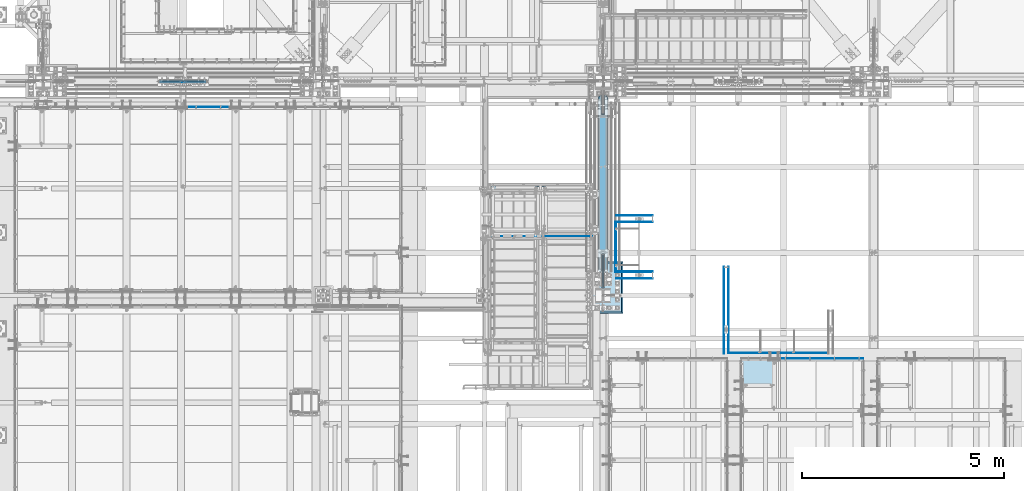
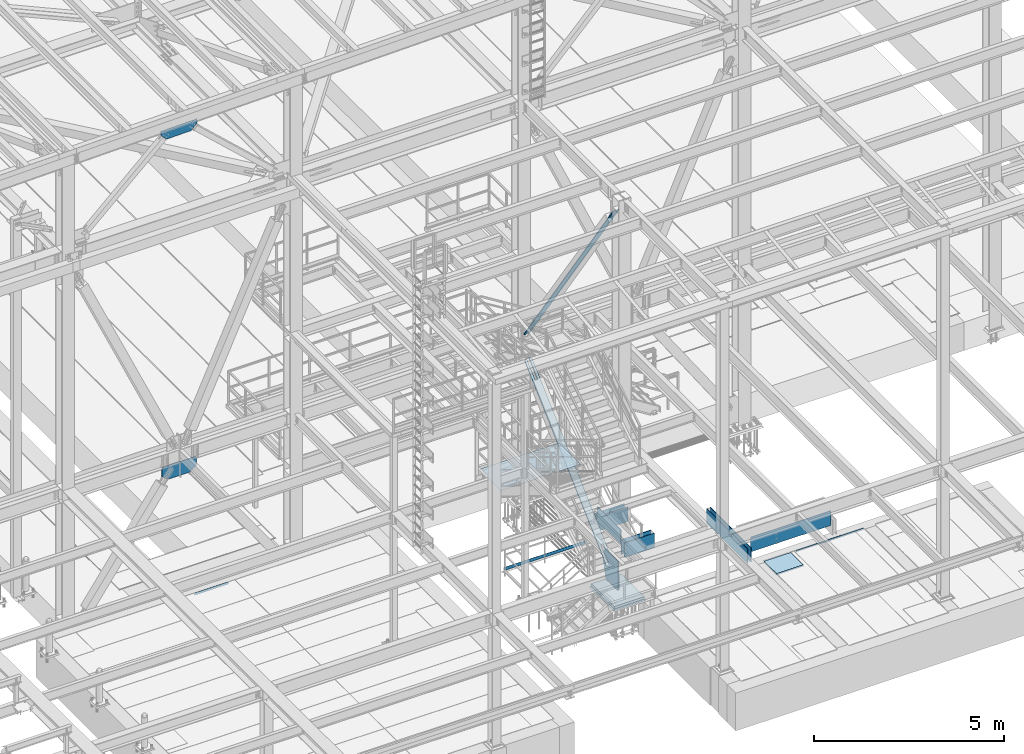
# One storey, part 2971 of 3843: 20 plates, 19 elements without a shape of their own.
"""IFC2X3 building model written with IfcOpenShell, lengths in millimetres."""

from ifc_helpers import new_model, si_unit, frame, origin_with_axes, place, context, subcontext, project, spatial, faceted_brep, material, type_object, element, aggregate, save


model = new_model("IFC2X3")

# Units and contexts
model_context = context("Model", 3, precision=1e-05, world=origin_with_axes())
body_context = subcontext(model_context, "Body", "Model", "MODEL_VIEW")
ifc_project = project(units=[si_unit("LENGTHUNIT", "METRE", prefix="MILLI"), si_unit("AREAUNIT", "SQUARE_METRE"), si_unit("VOLUMEUNIT", "CUBIC_METRE"), si_unit("MASSUNIT", "GRAM", prefix="KILO"), si_unit("TIMEUNIT", "SECOND"), si_unit("PLANEANGLEUNIT", "RADIAN"), si_unit("SOLIDANGLEUNIT", "STERADIAN"), si_unit("THERMODYNAMICTEMPERATUREUNIT", "DEGREE_CELSIUS"), si_unit("LUMINOUSINTENSITYUNIT", "LUMEN")], contexts=[model_context])

# Site, building, storey
site_placement = place(None, origin_with_axes())
site = spatial("IfcSite", under=ifc_project, at=site_placement, CompositionType="ELEMENT")
building_placement = place(site_placement, origin_with_axes())
building = spatial("IfcBuilding", under=site, at=building_placement, Name="Undefined", CompositionType="ELEMENT")
storey_placement = place(building_placement, origin_with_axes())
storey = spatial("IfcBuildingStorey", under=building, at=storey_placement, Name="Undefined", CompositionType="ELEMENT", Elevation=0.0)

# Assembly, plate
assembly_1_placement = place(storey_placement, origin_with_axes())
assembly_1 = element("IfcElementAssembly", 1, at=assembly_1_placement, inside=storey, AssemblyPlace="NOTDEFINED", PredefinedType="NOTDEFINED")
ifc_material_1 = material(Name="Drywall")
plate_type_1 = type_object("IfcPlateType", PredefinedType="NOTDEFINED")
plate_1_placement = place(assembly_1_placement, frame((58921.2137338943, 18872.2000000001, 30714.95), z_axis=(0.99999999999732, 2.31500000154483e-06, 0.0), x_axis=(-2.31499999993709e-06, 0.99999999999732, 0.0)))
plate_1 = element("IfcPlate", 2, at=plate_1_placement, type_object=plate_type_1, material=ifc_material_1, context=body_context, shape_type="Brep", body=[
    faceted_brep([(3.63797880709171e-12, -234.950000000001, -1.45519152283669e-11), (-7.41896983527113e-05, -234.950000000001, 15.8794303937975), (-7.41896983527113e-05, 234.950000000001, 15.8794303937975), (3.63797880709171e-12, 234.950000000001, -1.45519152283669e-11), (2146.3011990534, -234.950000000001, 15.8843994176204), (2146.3011990534, 234.950000000001, 15.8843994176204), (2146.30123583576, -234.950000000001, 3.33966454491019e-09), (2146.30123583576, 234.950000000001, 3.33966454491019e-09)], [[[0, 1, 2, 3]], [[1, 4, 5, 2]], [[4, 6, 7, 5]], [[6, 0, 3, 7]], [[5, 7, 3, 2]], [[6, 4, 1, 0]]]),
])
aggregate(assembly_1, [plate_1])

assembly_2_placement = place(storey_placement, origin_with_axes())
assembly_2 = element("IfcElementAssembly", 3, at=assembly_2_placement, inside=storey, AssemblyPlace="NOTDEFINED", PredefinedType="NOTDEFINED")
plate_2_placement = place(assembly_2_placement, frame((56254.6500010535, 22120.2773570658, 30714.95), z_axis=(4.67099999962315e-06, 0.999999999989091, 0.0), x_axis=(0.999999999985138, -5.45199999894105e-06, 0.0)))
plate_2 = element("IfcPlate", 4, at=plate_2_placement, type_object=plate_type_1, material=ifc_material_1, context=body_context, shape_type="Brep", body=[
    faceted_brep([(3.63797880709171e-12, -234.950000000001, -1.45519152283669e-11), (-7.41896983527113e-05, -234.950000000001, 15.8794303937975), (-7.41896983527113e-05, 234.950000000001, 15.8794303937975), (3.63797880709171e-12, 234.950000000001, -1.45519152283669e-11), (911.293316277799, -234.950000000001, 15.8843994149647), (911.293316277799, 234.950000000001, 15.8843994149647), (911.293402881587, -234.950000000001, 1.12049747258425e-09), (911.293402881587, 234.950000000001, 1.12049747258425e-09)], [[[0, 1, 2, 3]], [[1, 4, 5, 2]], [[4, 6, 7, 5]], [[6, 0, 3, 7]], [[5, 7, 3, 2]], [[6, 4, 1, 0]]]),
])
aggregate(assembly_2, [plate_2])

assembly_3_placement = place(storey_placement, origin_with_axes())
assembly_3 = element("IfcElementAssembly", 5, at=assembly_3_placement, inside=storey, AssemblyPlace="NOTDEFINED", PredefinedType="NOTDEFINED")
plate_3_placement = place(assembly_3_placement, frame((56254.6500010535, 22288.5523570658, 30714.95), z_axis=(4.67099999962315e-06, 0.999999999989091, 0.0), x_axis=(0.999999999985138, -5.45199999894105e-06, 0.0)))
plate_3 = element("IfcPlate", 6, at=plate_3_placement, type_object=plate_type_1, material=ifc_material_1, context=body_context, shape_type="Brep", body=[
    faceted_brep([(3.63797880709171e-12, -234.950000000001, -1.45519152283669e-11), (-7.41896983527113e-05, -234.950000000001, 15.8794303937975), (-7.41896983527113e-05, 234.950000000001, 15.8794303937975), (3.63797880709171e-12, 234.950000000001, -1.45519152283669e-11), (911.293316277799, -234.950000000001, 15.8843994149647), (911.293316277799, 234.950000000001, 15.8843994149647), (911.293402881587, -234.950000000001, 1.12049747258425e-09), (911.293402881587, 234.950000000001, 1.12049747258425e-09)], [[[0, 1, 2, 3]], [[1, 4, 5, 2]], [[4, 6, 7, 5]], [[6, 0, 3, 7]], [[5, 7, 3, 2]], [[6, 4, 1, 0]]]),
])
aggregate(assembly_3, [plate_3])

assembly_4_placement = place(storey_placement, origin_with_axes())
assembly_4 = element("IfcElementAssembly", 7, at=assembly_4_placement, inside=storey, AssemblyPlace="NOTDEFINED", PredefinedType="NOTDEFINED")
plate_4_placement = place(assembly_4_placement, frame((56254.6499999348, 20723.2495811391, 30714.95), z_axis=(4.67099999962315e-06, 0.999999999989091, 0.0), x_axis=(0.999999999985138, -5.45199999894105e-06, 0.0)))
plate_4 = element("IfcPlate", 8, at=plate_4_placement, type_object=plate_type_1, material=ifc_material_1, context=body_context, shape_type="Brep", body=[
    faceted_brep([(3.63797880709171e-12, -234.950000000001, -1.45519152283669e-11), (-7.41896983527113e-05, -234.950000000001, 15.8794303937975), (-7.41896983527113e-05, 234.950000000001, 15.8794303937975), (3.63797880709171e-12, 234.950000000001, -1.45519152283669e-11), (911.293316277799, -234.950000000001, 15.8843994149647), (911.293316277799, 234.950000000001, 15.8843994149647), (911.293402881587, -234.950000000001, 1.12049747258425e-09), (911.293402881587, 234.950000000001, 1.12049747258425e-09)], [[[0, 1, 2, 3]], [[1, 4, 5, 2]], [[4, 6, 7, 5]], [[6, 0, 3, 7]], [[5, 7, 3, 2]], [[6, 4, 1, 0]]]),
])
aggregate(assembly_4, [plate_4])

assembly_5_placement = place(storey_placement, origin_with_axes())
assembly_5 = element("IfcElementAssembly", 9, at=assembly_5_placement, inside=storey, AssemblyPlace="NOTDEFINED", PredefinedType="NOTDEFINED")
plate_5_placement = place(assembly_5_placement, frame((56254.6499999348, 20891.5245811391, 30714.95), z_axis=(4.67099999962315e-06, 0.999999999989091, 0.0), x_axis=(0.999999999985138, -5.45199999894105e-06, 0.0)))
plate_5 = element("IfcPlate", 10, at=plate_5_placement, type_object=plate_type_1, material=ifc_material_1, context=body_context, shape_type="Brep", body=[
    faceted_brep([(3.63797880709171e-12, -234.950000000001, -1.45519152283669e-11), (-7.41896983527113e-05, -234.950000000001, 15.8794303937975), (-7.41896983527113e-05, 234.950000000001, 15.8794303937975), (3.63797880709171e-12, 234.950000000001, -1.45519152283669e-11), (911.293316277799, -234.950000000001, 15.8843994149647), (911.293316277799, 234.950000000001, 15.8843994149647), (911.293402881587, -234.950000000001, 1.12049747258425e-09), (911.293402881587, 234.950000000001, 1.12049747258425e-09)], [[[0, 1, 2, 3]], [[1, 4, 5, 2]], [[4, 6, 7, 5]], [[6, 0, 3, 7]], [[5, 7, 3, 2]], [[6, 4, 1, 0]]]),
])
aggregate(assembly_5, [plate_5])

assembly_6_placement = place(storey_placement, origin_with_axes())
assembly_6 = element("IfcElementAssembly", 11, at=assembly_6_placement, inside=storey, AssemblyPlace="NOTDEFINED", PredefinedType="NOTDEFINED")
plate_6_placement = place(assembly_6_placement, frame((59030.3543588943, 18875.3750000001, 30714.95), z_axis=(0.99999999999732, 2.31500000154483e-06, 0.0), x_axis=(-2.31499999993709e-06, 0.99999999999732, 0.0)))
plate_6 = element("IfcPlate", 12, at=plate_6_placement, type_object=plate_type_1, material=ifc_material_1, context=body_context, shape_type="Brep", body=[
    faceted_brep([(3.63797880709171e-12, -234.950000000001, -1.45519152283669e-11), (-7.41896983527113e-05, -234.950000000001, 15.8794303937975), (-7.41896983527113e-05, 234.950000000001, 15.8794303937975), (3.63797880709171e-12, 234.950000000001, -1.45519152283669e-11), (2143.12619898679, -234.950000000001, 15.8843994249401), (2143.12619898679, 234.950000000001, 15.8843994249401), (2143.12623582349, -234.950000000001, 1.03973434306681e-08), (2143.12623582349, 234.950000000001, 1.03973434306681e-08)], [[[0, 1, 2, 3]], [[1, 4, 5, 2]], [[4, 6, 7, 5]], [[6, 0, 3, 7]], [[5, 7, 3, 2]], [[6, 4, 1, 0]]]),
])
aggregate(assembly_6, [plate_6])

assembly_7_placement = place(storey_placement, origin_with_axes())
assembly_7 = element("IfcElementAssembly", 13, at=assembly_7_placement, inside=storey, Name="ANGLE", AssemblyPlace="NOTDEFINED", PredefinedType="RIGID_FRAME")
ifc_material_2 = material(Name="STEEL/A36")
plate_type_2 = type_object("IfcPlateType", PredefinedType="NOTDEFINED")
plate_7_placement = place(assembly_7_placement, frame((45640.6242810803, 24984.0750000327, 30403.8000030518), z_axis=(1.0, 0.0, 0.0), x_axis=(0.0, 0.0, 1.0)))
plate_7 = element("IfcPlate", 14, at=plate_7_placement, type_object=plate_type_2, material=ifc_material_2, Name="PLATE", context=body_context, shape_type="Brep", body=[
    faceted_brep([(0.0, -3.17499999999927, 0.0), (-2.04593234229833e-05, -3.17499999999927, 1022.33319091797), (-2.04593234229833e-05, 3.17499999999927, 1022.33319091797), (0.0, 3.17499999999927, 0.0), (76.1999816897733, -3.17499999999927, 1022.33319091822), (76.1999816897733, 3.17499999999927, 1022.33319091822), (76.1999999999971, -3.17499999999927, 0.0), (76.1999999999971, 3.17499999999927, 0.0)], [[[0, 1, 2, 3]], [[1, 4, 5, 2]], [[4, 6, 7, 5]], [[6, 0, 3, 7]], [[5, 7, 3, 2]], [[6, 4, 1, 0]]]),
])
aggregate(assembly_7, [plate_7])

assembly_8_placement = place(storey_placement, origin_with_axes())
assembly_8 = element("IfcElementAssembly", 15, at=assembly_8_placement, inside=storey, AssemblyPlace="NOTDEFINED", PredefinedType="NOTDEFINED")
ifc_material_3 = material(Name="TIMBER/PLYWOOD")
plate_type_3 = type_object("IfcPlateType", PredefinedType="NOTDEFINED")
plate_8_placement = place(assembly_8_placement, frame((56254.6499999348, 20891.5245811391, 31045.15), z_axis=(0.0, 1.0, 0.0), x_axis=(-1.0, 0.0, 0.0)))
plate_8 = element("IfcPlate", 16, at=plate_8_placement, type_object=plate_type_3, material=ifc_material_3, context=body_context, shape_type="Brep", body=[
    faceted_brep([(3.63797880709171e-12, -234.950000000001, -1.45519152283669e-11), (-1.18181196739897e-06, -234.950000000001, 1244.63220632034), (-1.18181196739897e-06, 234.950000000001, 1244.63220632034), (3.63797880709171e-12, 234.950000000001, -1.45519152283669e-11), (19.0499988181837, -234.950000000001, 1244.63220632034), (19.0499988181837, 234.950000000001, 1244.63220632034), (19.0499999999956, -234.950000000001, 0.0), (19.0499999999956, 234.950000000001, 0.0)], [[[0, 1, 2, 3]], [[1, 4, 5, 2]], [[4, 6, 7, 5]], [[6, 0, 3, 7]], [[5, 7, 3, 2]], [[6, 4, 1, 0]]]),
])
aggregate(assembly_8, [plate_8])

assembly_9_placement = place(storey_placement, origin_with_axes())
assembly_9 = element("IfcElementAssembly", 17, at=assembly_9_placement, inside=storey, AssemblyPlace="NOTDEFINED", PredefinedType="NOTDEFINED")
plate_9_placement = place(assembly_9_placement, frame((59030.3543588943, 18897.6, 31045.15), z_axis=(1.0, 0.0, 0.0), x_axis=(0.0, -1.0, 0.0)))
plate_9 = element("IfcPlate", 18, at=plate_9_placement, type_object=plate_type_3, material=ifc_material_3, context=body_context, shape_type="Brep", body=[
    faceted_brep([(3.63797880709171e-12, -234.950000000001, -1.45519152283669e-11), (-6.93082256475464e-07, -234.950000000001, 2438.7415893182), (-6.93082256475464e-07, 234.950000000001, 2438.7415893182), (3.63797880709171e-12, 234.950000000001, -1.45519152283669e-11), (19.0499993068843, -234.950000000001, 2438.74158932541), (19.0499993068843, 234.950000000001, 2438.74158932541), (19.0499999999956, -234.950000000001, 0.0), (19.0499999999956, 234.950000000001, 0.0)], [[[0, 1, 2, 3]], [[1, 4, 5, 2]], [[4, 6, 7, 5]], [[6, 0, 3, 7]], [[5, 7, 3, 2]], [[6, 4, 1, 0]]]),
])
aggregate(assembly_9, [plate_9])

assembly_10_placement = place(storey_placement, origin_with_axes())
assembly_10 = element("IfcElementAssembly", 19, at=assembly_10_placement, inside=storey, Name="ANGLE", AssemblyPlace="NOTDEFINED", PredefinedType="RIGID_FRAME")
plate_type_4 = type_object("IfcPlateType", PredefinedType="NOTDEFINED")
plate_10_placement = place(assembly_10_placement, frame((60337.6998506248, 18751.5500110765, 30429.2000030518), z_axis=(1.0, 0.0, 0.0), x_axis=(0.0, 0.0, 1.0)))
plate_10 = element("IfcPlate", 20, at=plate_10_placement, type_object=plate_type_4, material=ifc_material_2, Name="PLATE", context=body_context, shape_type="Brep", body=[
    faceted_brep([(0.0, -3.17499999999927, 0.0), (-5.47431700397283e-05, -3.17499999999927, 2044.69995117187), (-5.47431700397283e-05, 3.17499999999927, 2044.69995117187), (0.0, 3.17499999999927, 0.0), (50.7999496465127, -3.17499999999927, 2044.69995117185), (50.7999496465127, 3.17499999999927, 2044.69995117185), (50.7999954217848, -3.17499999999563, -7.27595761418343e-12), (50.7999954217848, 3.17500000001019, -1.09139364212751e-11)], [[[0, 1, 2, 3]], [[1, 4, 5, 2]], [[4, 6, 7, 5]], [[6, 0, 3, 7]], [[5, 7, 3, 2]], [[6, 4, 1, 0]]]),
])
aggregate(assembly_10, [plate_10])

assembly_11_placement = place(storey_placement, origin_with_axes())
assembly_11 = element("IfcElementAssembly", 21, at=assembly_11_placement, inside=storey, Name="RAIL", AssemblyPlace="NOTDEFINED", PredefinedType="RIGID_FRAME")
plate_type_5 = type_object("IfcPlateType", PredefinedType="NOTDEFINED")
plate_11_placement = place(assembly_11_placement, frame((55657.7499998292, 21777.3249999874, 30492.7), z_axis=(0.0, 0.0, 1.0), x_axis=(-1.0, 0.0, 0.0)))
plate_11 = element("IfcPlate", 22, at=plate_11_placement, type_object=plate_type_5, material=ifc_material_2, Name="TOE_PLATE", context=body_context, shape_type="Brep", body=[
    faceted_brep([(0.0, -3.17499999999927, 0.0), (0.0, -3.17499999999927, 101.600000000006), (0.0, 3.17499999999927, 101.600000000006), (0.0, 3.17499999999927, 0.0), (2463.80000059424, -3.17499999999927, 101.599999999999), (2463.80000059424, 3.17499999999927, 101.599999999999), (2463.80000059424, -3.17499999999927, 0.0), (2463.80000059424, 3.17499999999927, 0.0)], [[[0, 1, 2, 3]], [[1, 4, 5, 2]], [[4, 6, 7, 5]], [[6, 0, 3, 7]], [[5, 7, 3, 2]], [[6, 4, 1, 0]]]),
])
aggregate(assembly_11, [plate_11])

assembly_12_placement = place(storey_placement, origin_with_axes())
assembly_12 = element("IfcElementAssembly", 23, at=assembly_12_placement, inside=storey, Name="PAN", AssemblyPlace="NOTDEFINED", PredefinedType="RIGID_FRAME")
ifc_material_4 = material(Name="STEEL/ASTM A1011")
plate_type_6 = type_object("IfcPlateType", PredefinedType="NOTDEFINED")
plate_12_placement = place(assembly_12_placement, frame((55594.250000001, 23018.7500000005, 33009.8644213185), z_axis=(0.0, -1.0, 0.0), x_axis=(-1.0, 0.0, 0.0)))
plate_12 = element("IfcPlate", 24, at=plate_12_placement, type_object=plate_type_6, material=ifc_material_4, Name="PAN", context=body_context, shape_type="Brep", body=[
    faceted_brep([(1098.55000000101, -1.58750000000146, 1136.64999999481), (1098.55000000102, -1.58750000000146, 1104.89999999687), (1098.55000000102, 1.58750000000146, 1104.89999999687), (1098.55000000101, 1.58750000000146, 1136.64999999481), (1327.14999997777, -1.58750000000146, 1104.89999999731), (1327.14999997777, 1.58750000000146, 1104.89999999731), (1327.14999997777, -1.58750000000146, 1136.64999999489), (1327.14999997777, 1.58750000000146, 1136.64999999481), (0.0, -1.58750000000146, 0.0), (0.0, -1.58750000000146, 1136.64999999481), (0.0, 1.58750000000146, 1136.64999999481), (0.0, 1.58750000000146, 0.0), (2425.69999999949, -1.58750000000146, 7.27595761418343e-12), (2425.69999999949, 1.58750000000146, 7.27595761418343e-12), (2425.69999999949, -1.58750000000146, 1136.64999999481), (2425.69999999949, 1.58750000000146, 1136.64999999481)], [[[0, 1, 2, 3]], [[4, 5, 2, 1]], [[6, 7, 5, 4]], [[8, 9, 10, 11]], [[12, 8, 11, 13]], [[14, 12, 13, 15]], [[1, 0, 9, 8, 12, 14, 6, 4]], [[10, 9, 0, 3]], [[15, 13, 11, 10, 3, 2, 5, 7]], [[14, 15, 7, 6]]]),
])
aggregate(assembly_12, [plate_12])

assembly_13_placement = place(storey_placement, origin_with_axes())
assembly_13 = element("IfcElementAssembly", 25, at=assembly_13_placement, inside=storey, Name="COLUMN", AssemblyPlace="NOTDEFINED", PredefinedType="RIGID_FRAME")
ifc_material_5 = material(Name="STEEL/A572-50")
plate_type_7 = type_object("IfcPlateType", PredefinedType="NOTDEFINED")
plate_13_placement = place(assembly_13_placement, frame((55930.8, 20486.6875, 29679.9), z_axis=(0.0, 0.0, 1.0), x_axis=(0.0, 1.0, 0.0)))
plate_13 = element("IfcPlate", 26, at=plate_13_placement, type_object=plate_type_7, material=ifc_material_5, Name="CB", context=body_context, shape_type="Brep", body=[
    faceted_brep([(0.0, -15.875, 19.0499992370605), (0.0, -15.875, 947.728951640373), (0.0, 15.875, 947.728951640373), (0.0, 15.875, 19.0499992370605), (643.915207091308, -15.875, 947.728951640373), (643.915207091308, 15.875, 947.728951640373), (831.249077650387, -15.875, 744.73567203154), (831.249077650387, 15.875, 744.73567203154), (633.412499999988, -15.875, -2.18278728425503e-11), (633.412499999988, 15.875, -2.18278728425503e-11), (19.0500015258804, -15.875, 0.0), (19.0500015258804, 15.875, 0.0)], [[[0, 1, 2, 3]], [[1, 4, 5, 2]], [[4, 6, 7, 5]], [[6, 8, 9, 7]], [[8, 10, 11, 9]], [[10, 0, 3, 11]], [[5, 7, 9, 11, 3, 2]], [[10, 8, 6, 4, 1, 0]]]),
])

assembly_14_placement = place(storey_placement, origin_with_axes())
assembly_14 = element("IfcElementAssembly", 27, at=assembly_14_placement, inside=storey, Name="CB", AssemblyPlace="NOTDEFINED", PredefinedType="RIGID_FRAME")
plate_type_8 = type_object("IfcPlateType", PredefinedType="NOTDEFINED")
plate_14_placement = place(assembly_14_placement, frame((55835.55, 25338.220285469, 34981.1323415512), z_axis=(0.0, -0.56819627680556, 0.82289306171841), x_axis=(1.0, 0.0, 0.0)))
plate_14 = element("IfcPlate", 28, at=plate_14_placement, type_object=plate_type_8, material=ifc_material_2, Name="CB", context=body_context, shape_type="Brep", body=[
    faceted_brep([(0.0, -12.7000000000553, 66.6750030518178), (0.0, -12.700000006007, 8303.11727470915), (0.0, 12.6999999940163, 8303.11727470916), (0.0, 12.699999999968, 66.675003051836), (5.07533240211342, -12.7000000060216, 8328.63269372997), (5.07533240211342, 12.6999999939944, 8328.63269372999), (19.528656258226, -12.7000000060361, 8350.26362150273), (19.528656258226, 12.6999999939799, 8350.26362150274), (41.1595840309601, -12.7000000060507, 8364.71694535885), (41.1595840309601, 12.6999999939726, 8364.71694535888), (66.6750000000029, -12.700000006058, 8369.79227776097), (66.6750000000029, 12.6999999939726, 8369.79227776098), (66.6750000000029, -12.7000000057014, 7883.77113890531), (66.6750000000029, 12.6999999943218, 7883.77113890533), (123.824999999997, -12.7000000057014, 7883.77113890531), (123.824999999997, 12.6999999943218, 7883.77113890533), (123.824996948242, -12.700000006058, 8369.79227776097), (123.824996948242, 12.6999999939726, 8369.79227776098), (149.34041596904, -12.7000000060507, 8364.71694535885), (149.34041596904, 12.6999999939726, 8364.71694535888), (170.971343741774, -12.7000000060361, 8350.26362150273), (170.971343741774, 12.6999999939799, 8350.26362150274), (185.424667597887, -12.7000000060216, 8328.63269372997), (185.424667597887, 12.6999999939944, 8328.63269372999), (190.5, -12.700000006007, 8303.11727470915), (190.5, 12.6999999940163, 8303.11727470916), (190.5, -12.7000000000553, 66.6750030518178), (190.5, 12.699999999968, 66.675003051836), (185.424667597887, -12.7000000000407, 41.159584030991), (185.424667597887, 12.6999999999825, 41.1595840310092), (170.971343741774, -12.7000000000262, 19.5286562582332), (170.971343741774, 12.6999999999971, 19.5286562582569), (149.34041596904, -12.7000000000116, 5.07533240210978), (149.34041596904, 12.7000000000044, 5.07533240212433), (123.824999999997, -12.7000000000116, -9.09494701772928e-12), (123.824999999997, 12.7000000000116, 1.09139364212751e-11), (123.824999999997, -12.7000000003609, 486.021138855645), (123.824999999997, 12.6999999996624, 486.021138855662), (66.6750000000029, -12.7000000003609, 486.021138855645), (66.6750000000029, 12.6999999996624, 486.021138855662), (66.6750030517578, -12.7000000000116, -9.09494701772928e-12), (66.6750030517578, 12.7000000000116, 1.09139364212751e-11), (41.1595840309601, -12.7000000000116, 5.07533240210978), (41.1595840309601, 12.7000000000044, 5.07533240212433), (19.528656258226, -12.7000000000262, 19.5286562582332), (19.528656258226, 12.6999999999971, 19.5286562582569), (5.07533240211342, -12.7000000000407, 41.159584030991), (5.07533240211342, 12.6999999999825, 41.1595840310092)], [[[0, 1, 2, 3]], [[1, 4, 5, 2]], [[4, 6, 7, 5]], [[6, 8, 9, 7]], [[8, 10, 11, 9]], [[10, 12, 13, 11]], [[12, 14, 15, 13]], [[14, 16, 17, 15]], [[16, 18, 19, 17]], [[18, 20, 21, 19]], [[20, 22, 23, 21]], [[22, 24, 25, 23]], [[24, 26, 27, 25]], [[26, 28, 29, 27]], [[28, 30, 31, 29]], [[30, 32, 33, 31]], [[32, 34, 35, 33]], [[34, 36, 37, 35]], [[36, 38, 39, 37]], [[38, 40, 41, 39]], [[40, 42, 43, 41]], [[42, 44, 45, 43]], [[44, 46, 47, 45]], [[46, 0, 3, 47]], [[5, 7, 9, 11, 13, 15, 17, 19, 21, 23, 25, 27, 29, 31, 33, 35, 37, 39, 41, 43, 45, 47, 3, 2]], [[46, 44, 42, 40, 38, 36, 34, 32, 30, 28, 26, 24, 22, 20, 18, 16, 14, 12, 10, 8, 6, 4, 1, 0]]]),
])
aggregate(assembly_14, [plate_14])

assembly_15_placement = place(storey_placement, origin_with_axes())
assembly_15 = element("IfcElementAssembly", 29, at=assembly_15_placement, inside=storey, Name="CB", AssemblyPlace="NOTDEFINED", PredefinedType="RIGID_FRAME")
plate_type_9 = type_object("IfcPlateType", PredefinedType="NOTDEFINED")
plate_15_placement = place(assembly_15_placement, frame((56043.5125, 20891.8946554706, 30219.3975623242), z_axis=(0.0, 0.734883807073284, 0.678193033067634), x_axis=(-1.0, 0.0, 0.0)))
plate_15 = element("IfcPlate", 30, at=plate_15_placement, type_object=plate_type_9, material=ifc_material_2, Name="CB", context=body_context, shape_type="Brep", body=[
    faceted_brep([(0.0, -15.8749999998581, 77.7874984741429), (0.0, -15.8749999892789, 5875.02723326095), (0.0, 15.8750000107175, 5875.02723326089), (0.0, 15.8750000001437, 77.7874984740847), (5.92122074862709, -15.8749999892243, 5904.79522017212), (5.92122074862709, 15.8750000107721, 5904.79522017207), (22.7834308115343, -15.874999989177, 5930.03130092355), (22.7834308115343, 15.875000010823, 5930.03130092349), (48.0195115629467, -15.8749999891479, 5946.89351098644), (48.0195115629467, 15.8750000108521, 5946.89351098639), (77.7874999999985, -15.8749999891334, 5952.81473173507), (77.7874999999985, 15.8750000108666, 5952.81473173502), (77.7874999999985, -15.8749999902757, 5329.08236586732), (77.7874999999985, 15.8750000097243, 5329.08236586725), (147.637500000004, -15.8749999902757, 5329.08236586732), (147.637500000004, 15.8750000097243, 5329.08236586725), (147.637501525882, -15.8749999891334, 5952.81473173507), (147.637501525882, 15.8750000108666, 5952.81473173502), (177.405488437056, -15.8749999891479, 5946.89351098644), (177.405488437056, 15.8750000108521, 5946.89351098639), (202.641569188469, -15.874999989177, 5930.03130092355), (202.641569188469, 15.875000010823, 5930.03130092349), (219.503779251376, -15.8749999892243, 5904.79522017212), (219.503779251376, 15.8750000107721, 5904.79522017207), (225.425000000003, -15.8749999892789, 5875.02723326095), (225.425000000003, 15.8750000107175, 5875.02723326089), (225.425000000003, -15.8749999998581, 77.7874984741429), (225.425000000003, 15.8750000001437, 77.7874984740847), (219.503779251376, -15.8749999999109, 48.0195115629685), (219.503779251376, 15.8750000000891, 48.0195115629249), (202.641569188469, -15.8749999999582, 22.7834308115562), (202.641569188469, 15.87500000004, 22.7834308115052), (177.405488437056, -15.8749999999891, 5.92122074864892), (177.405488437056, 15.8750000000109, 5.92122074859071), (147.637500000004, -15.8749999999982, 2.18278728425503e-11), (147.637500000004, 15.8750000000018, -2.91038304567337e-11), (147.637500000004, -15.8749999988613, 623.732365867771), (147.637500000004, 15.8750000011369, 623.732365867712), (77.7874999999985, -15.8749999988613, 623.732365867771), (77.7874999999985, 15.8750000011369, 623.732365867712), (77.7874984741211, -15.8749999999982, 2.18278728425503e-11), (77.7874984741211, 15.8750000000018, -2.91038304567337e-11), (48.0195115629467, -15.8749999999891, 5.92122074864892), (48.0195115629467, 15.8750000000109, 5.92122074859071), (22.7834308115343, -15.8749999999582, 22.7834308115562), (22.7834308115343, 15.87500000004, 22.7834308115052), (5.92122074862709, -15.8749999999109, 48.0195115629685), (5.92122074862709, 15.8750000000891, 48.0195115629249)], [[[0, 1, 2, 3]], [[1, 4, 5, 2]], [[4, 6, 7, 5]], [[6, 8, 9, 7]], [[8, 10, 11, 9]], [[10, 12, 13, 11]], [[12, 14, 15, 13]], [[14, 16, 17, 15]], [[16, 18, 19, 17]], [[18, 20, 21, 19]], [[20, 22, 23, 21]], [[22, 24, 25, 23]], [[24, 26, 27, 25]], [[26, 28, 29, 27]], [[28, 30, 31, 29]], [[30, 32, 33, 31]], [[32, 34, 35, 33]], [[34, 36, 37, 35]], [[36, 38, 39, 37]], [[38, 40, 41, 39]], [[40, 42, 43, 41]], [[42, 44, 45, 43]], [[44, 46, 47, 45]], [[46, 0, 3, 47]], [[5, 7, 9, 11, 13, 15, 17, 19, 21, 23, 25, 27, 29, 31, 33, 35, 37, 39, 41, 43, 45, 47, 3, 2]], [[46, 44, 42, 40, 38, 36, 34, 32, 30, 28, 26, 24, 22, 20, 18, 16, 14, 12, 10, 8, 6, 4, 1, 0]]]),
])
aggregate(assembly_15, [plate_15])

assembly_16_placement = place(storey_placement, origin_with_axes())
assembly_16 = element("IfcElementAssembly", 31, at=assembly_16_placement, inside=storey, Name="GRATING", AssemblyPlace="NOTDEFINED", PredefinedType="NOTDEFINED")
ifc_material_6 = material()
plate_type_10 = type_object("IfcPlateType", PredefinedType="NOTDEFINED")
plate_16_placement = place(assembly_16_placement, frame((59359.7998072089, 18742.0248046875, 30454.6), z_axis=(1.0, 0.0, 0.0), x_axis=(0.0, -1.0, 0.0)))
plate_16 = element("IfcPlate", 32, at=plate_16_placement, type_object=plate_type_10, material=ifc_material_6, Name="GRATING", context=body_context, shape_type="Brep", body=[
    faceted_brep([(0.0, -25.3999996185303, 0.0), (7.50295293983072e-05, -25.4000000000015, 809.625126565414), (7.50295293983072e-05, 25.4000000000015, 809.625126565414), (0.0, 25.3999996185303, 0.0), (657.224826183392, -25.4000000000015, 809.625108328517), (657.224826183392, 25.4000000000015, 809.625108328517), (657.224804701837, -25.4000000000015, 5.67524693906307e-10), (657.224804701837, 25.4000000000015, 5.67524693906307e-10)], [[[0, 1, 2, 3]], [[1, 4, 5, 2]], [[4, 6, 7, 5]], [[6, 0, 3, 7]], [[5, 7, 3, 2]], [[6, 4, 1, 0]]]),
])
aggregate(assembly_16, [plate_16])

assembly_17_placement = place(storey_placement, origin_with_axes())
assembly_17 = element("IfcElementAssembly", 33, at=assembly_17_placement, inside=storey, Name="BEAM", AssemblyPlace="NOTDEFINED", PredefinedType="RIGID_FRAME")
plate_type_11 = type_object("IfcPlateType", PredefinedType="NOTDEFINED")
plate_17_placement = place(assembly_17_placement, frame((45005.9470009143, 25615.9, 34053.5304499466), z_axis=(1.0, 0.0, 0.0), x_axis=(0.0, 0.0, 1.0)))
plate_17 = element("IfcPlate", 34, at=plate_17_placement, type_object=plate_type_11, material=ifc_material_5, Name="CB", context=body_context, shape_type="Brep", body=[
    faceted_brep([(0.0, -12.6999999999971, 0.0), (-141.167281474489, -12.7000000000007, 199.599159681035), (-141.167281474489, 12.7000000000007, 199.599159681035), (0.0, 12.6999999999971, 0.0), (-141.167281474489, -12.7000000000007, 529.902999085745), (-141.167281474489, 12.7000000000007, 529.902999085745), (-141.167281474489, -12.7000000000007, 847.506838956775), (-141.167281474489, 12.7000000000007, 847.506838956775), (-3.29811882693321e-07, -12.7000000000007, 1047.10599817149), (-3.29811882693321e-07, 12.7000000000007, 1047.10599817149), (299.969550053422, -12.7000000000007, 1047.10599817149), (299.969550053422, 12.7000000000007, 1047.10599817149), (299.969550053422, -12.7000000000007, 0.0), (299.969550053422, 12.7000000000007, 0.0)], [[[0, 1, 2, 3]], [[1, 4, 5, 2]], [[4, 6, 7, 5]], [[6, 8, 9, 7]], [[8, 10, 11, 9]], [[10, 12, 13, 11]], [[12, 0, 3, 13]], [[5, 7, 9, 11, 13, 3, 2]], [[12, 10, 8, 6, 4, 1, 0]]]),
])
aggregate(assembly_17, [plate_17])

assembly_18_placement = place(storey_placement, origin_with_axes())
assembly_18 = element("IfcElementAssembly", 35, at=assembly_18_placement, inside=storey, Name="BEAM", AssemblyPlace="NOTDEFINED", PredefinedType="RIGID_FRAME")
plate_type_12 = type_object("IfcPlateType", PredefinedType="NOTDEFINED")
plate_18_placement = place(assembly_18_placement, frame((44967.1521121187, 25603.1999999454, 45179.8871172699), z_axis=(0.0211520550054438, 0.0, -0.999776270257025), x_axis=(0.999776270257024, 0.0, 0.0211520550054619)))
plate_18 = element("IfcPlate", 36, at=plate_18_placement, type_object=plate_type_12, material=ifc_material_5, context=body_context, shape_type="Brep", body=[
    faceted_brep([(0.0, -6.3499999046162, 0.0), (1.30967237055302e-10, -6.34999999999854, 124.231505217977), (1.30967237055302e-10, 6.34999999999854, 124.231505217977), (7.27595761418343e-12, 6.3499999046162, 0.0), (168.357662325194, -6.34999999999854, 314.420089354382), (168.357662325194, 6.34999999999854, 314.420089354382), (923.858874949481, -6.34999999999854, 314.420089353633), (923.858874949481, 6.34999999999854, 314.420089353633), (1101.10861422466, -6.34999999999854, 130.485915310033), (1101.10861422466, 6.34999999999854, 130.485915310033), (1101.10861422453, -6.34999999999854, -1.10594555735588e-09), (1101.10861422453, 6.34999999999854, -1.10594555735588e-09)], [[[0, 1, 2, 3]], [[1, 4, 5, 2]], [[4, 6, 7, 5]], [[6, 8, 9, 7]], [[8, 10, 11, 9]], [[10, 0, 3, 11]], [[5, 7, 9, 11, 3, 2]], [[10, 8, 6, 4, 1, 0]]]),
])
aggregate(assembly_18, [plate_18])

assembly_19_placement = place(storey_placement, origin_with_axes())
assembly_19 = element("IfcElementAssembly", 37, at=assembly_19_placement, inside=storey, Name="GROUT", AssemblyPlace="NOTDEFINED", PredefinedType="REINFORCEMENT_UNIT")
ifc_material_7 = material(Name="CONCRETE/Concrete_Undefined")
plate_type_13 = type_object("IfcPlateType", PredefinedType="NOTDEFINED")
plate_19_placement = place(assembly_19_placement, frame((55435.5, 21158.2, 29584.65), z_axis=(1.0, 0.0, 0.0), x_axis=(0.0, -1.0, 0.0)))
plate_19 = element("IfcPlate", 38, at=plate_19_placement, type_object=plate_type_13, material=ifc_material_7, Name="GROUT", context=body_context, shape_type="Brep", body=[
    faceted_brep([(38.0999999997875, -19.0499999997883, 952.500000000204), (0.0, 19.0499999999993, 990.599975585938), (0.0, 19.0500000000029, 0.0), (38.1000000006916, -19.0499999999811, 38.1000000006607), (1257.3000000002, -19.0499999998065, 38.0999999998021), (1295.40002441406, 19.0499999999993, 0.0), (1295.40002441406, 19.0499999999993, 990.599975585938), (1257.3000000002, -19.049999999992, 952.500000000204)], [[[0, 1, 2, 3]], [[4, 5, 6, 7]], [[4, 7, 0, 3]], [[5, 4, 3, 2]], [[6, 5, 2, 1]], [[7, 6, 1, 0]]]),
])
aggregate(assembly_19, [plate_19])

# Plate
plate_type_14 = type_object("IfcPlateType", PredefinedType="NOTDEFINED")
plate_20_placement = place(assembly_13_placement, frame((55473.6, 21120.1, 29641.8), z_axis=(1.0, 0.0, 0.0), x_axis=(0.0, -1.0, 0.0)))
plate_20 = element("IfcPlate", 39, at=plate_20_placement, type_object=plate_type_14, material=ifc_material_5, Name="PLATE", context=body_context, shape_type="Brep", body=[
    faceted_brep([(0.0, -38.0999999999985, 0.0), (0.0, -38.0999999999985, 914.400024414062), (0.0, 38.0999999999985, 914.400024414062), (0.0, 38.0999999999985, 0.0), (1219.19995117188, -38.0999999999985, 914.400024414062), (1219.19995117188, 38.0999999999985, 914.400024414062), (1219.19995117188, -38.0999999999985, 0.0), (1219.19995117188, 38.0999999999985, 0.0)], [[[0, 1, 2, 3]], [[1, 4, 5, 2]], [[4, 6, 7, 5]], [[6, 0, 3, 7]], [[5, 7, 3, 2]], [[6, 4, 1, 0]]]),
])

aggregate(assembly_13, [plate_13, plate_20])

save(model, "model.ifc")
